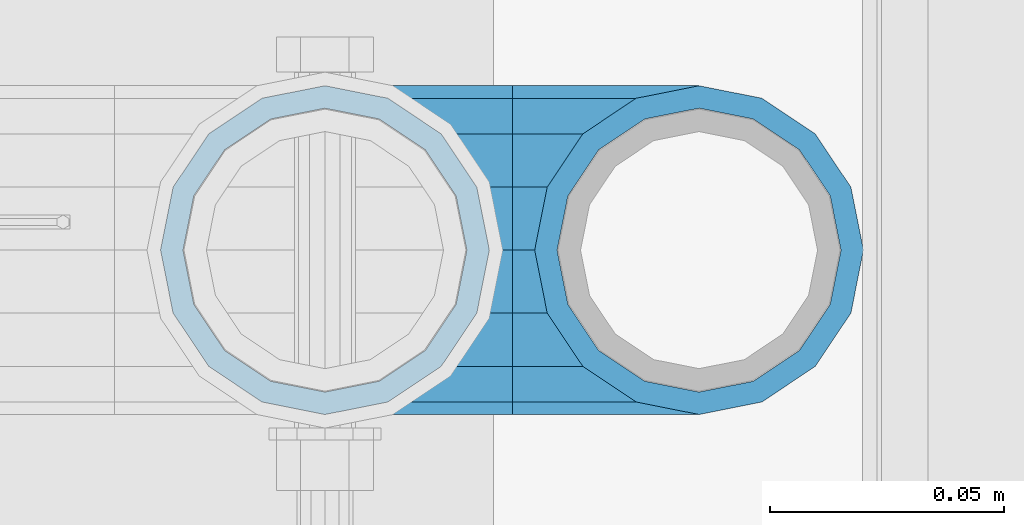
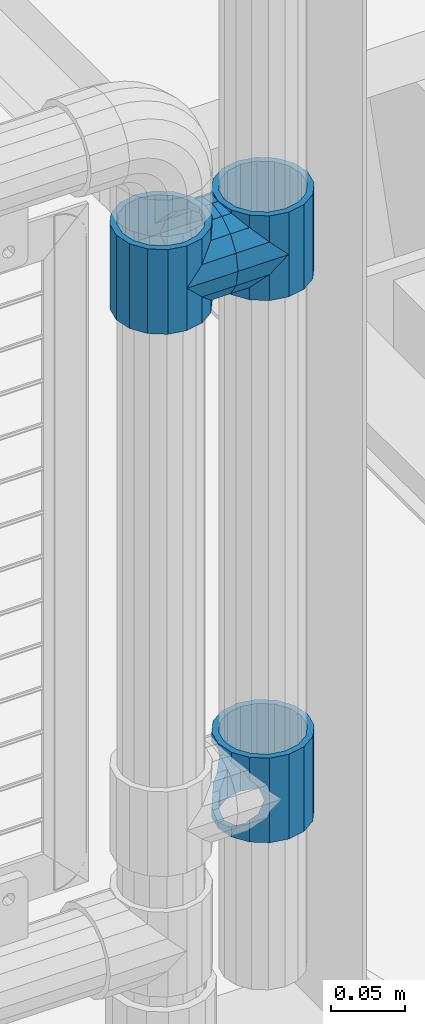
# One storey, part 174 of 257: 5 beams.
"""IFC2X3 building model written with IfcOpenShell, lengths in millimetres."""

import ifcopenshell
import ifcopenshell.guid

model = None  # the IFC model being written
_history = None  # IfcOwnerHistory: only IFC2X3 demands one
_inside = {}  # id of a spatial element -> (the spatial element, [elements in it])
_under = {}  # id of a project, library or spatial element -> (it, [spatial elements below it])
_declared = {}  # id of a project -> (the project, [libraries it declares])
_typed = {}  # id of a type object -> (the type object, [elements of that type])
_made_of = {}  # id of a material, layer set ... -> (it, [elements and type objects made of it])


def new_model(schema):
    """Start an empty IFC model of exactly this schema.

    Asked for "IFC4X3", IfcOpenShell would pick the latest addendum, in which some entities
    have other attributes; the version numbers below select the first issue.
    IFC2X3 requires an IfcOwnerHistory on every rooted entity: one is made here for all.
    """
    global model, _history
    if schema == "IFC4X3":
        model = ifcopenshell.file(schema_version=(4, 3, 0, 0))
    else:
        model = ifcopenshell.file(schema=schema)
    _inside.clear()
    _under.clear()
    _declared.clear()
    _typed.clear()
    _made_of.clear()
    _history = None
    if model.schema == "IFC2X3":
        org = make("IfcOrganization", Name="unknown")
        user = make(
            "IfcPersonAndOrganization",
            ThePerson=make("IfcPerson", FamilyName="unknown"),
            TheOrganization=org,
        )
        app = make(
            "IfcApplication",
            ApplicationDeveloper=org,
            Version="unknown",
            ApplicationFullName="unknown",
            ApplicationIdentifier="unknown",
        )
        _history = make(
            "IfcOwnerHistory",
            OwningUser=user,
            OwningApplication=app,
            ChangeAction="ADDED",
            CreationDate=0,
        )
    return model


def make(cls, **values):
    """One entity of the class cls with the attributes given. An attribute that is None is left unset."""
    return model.create_entity(
        cls, **{name: value for name, value in values.items() if value is not None}
    )


def rooted(cls, **values):
    """An entity with a GlobalId (a new one), such as an element, a storey or a relation."""
    return make(cls, GlobalId=ifcopenshell.guid.new(), OwnerHistory=_history, **values)


def si_unit(unit_type, name, prefix=None):
    """IfcSIUnit, for example si_unit("LENGTHUNIT", "METRE", prefix="MILLI")."""
    return make("IfcSIUnit", UnitType=unit_type, Prefix=prefix, Name=name)


def assignment(units):
    """IfcUnitAssignment: the units of a project."""
    return None if units is None else make("IfcUnitAssignment", Units=units)


def point(xyz):
    """IfcCartesianPoint."""
    return None if xyz is None else make("IfcCartesianPoint", Coordinates=xyz)


def direction(xyz):
    """IfcDirection."""
    return None if xyz is None else make("IfcDirection", DirectionRatios=xyz)


def frame(location, z_axis=None, x_axis=None):
    """IfcAxis2Placement3D, a coordinate frame: its origin and axes. An axis left out is left unset."""
    return make(
        "IfcAxis2Placement3D",
        Location=point(location),
        Axis=direction(z_axis),
        RefDirection=direction(x_axis),
    )


def origin_with_axes():
    """The frame at (0, 0, 0) with the z axis (0, 0, 1) and the x axis (1, 0, 0) written out."""
    return frame((0.0, 0.0, 0.0), z_axis=(0.0, 0.0, 1.0), x_axis=(1.0, 0.0, 0.0))


def place(relative_to, where):
    """IfcLocalPlacement: puts the frame where relative to a parent placement (None: the world)."""
    return make(
        "IfcLocalPlacement", PlacementRelTo=relative_to, RelativePlacement=where
    )


def context(
    kind, dimensions, precision=None, world=None, true_north=None, identifier=None
):
    """IfcGeometricRepresentationContext, for example the 3D "Model" context."""
    return make(
        "IfcGeometricRepresentationContext",
        ContextIdentifier=identifier,
        ContextType=kind,
        CoordinateSpaceDimension=dimensions,
        Precision=precision,
        WorldCoordinateSystem=world,
        TrueNorth=true_north,
    )


def subcontext(parent, identifier, kind, view, scale=None):
    """IfcGeometricRepresentationSubContext, for example "Body" below "Model"."""
    return make(
        "IfcGeometricRepresentationSubContext",
        ContextIdentifier=identifier,
        ContextType=kind,
        ParentContext=parent,
        TargetScale=scale,
        TargetView=view,
    )


def project(units=None, contexts=None):
    """IfcProject with its units and contexts."""
    return rooted(
        "IfcProject",
        Name="project",
        RepresentationContexts=contexts,
        UnitsInContext=assignment(units),
    )


def spatial(cls, under=None, at=None, **own):
    """A site, building, storey or space (cls), placed at a placement, below another one or the project."""
    s = rooted(cls, ObjectPlacement=at, **own)
    if under is not None:
        _under.setdefault(under.id(), (under, []))[1].append(s)
    return s


def faces_of(points, faces, orient=None, outer=None):
    """IfcFace entities. A face is a list of loops; a loop is a list of indices into points, from 0.

    orient and outer hold one flag for each loop. By default every Orientation is true, the
    first loop of a face is its IfcFaceOuterBound and the others are IfcFaceBound.
    """
    made = []
    for i, loops in enumerate(faces):
        bounds = []
        for j, loop in enumerate(loops):
            is_outer = j == 0 if outer is None else outer[i][j]
            bounds.append(
                make(
                    "IfcFaceOuterBound" if is_outer else "IfcFaceBound",
                    Bound=make("IfcPolyLoop", Polygon=[points[k] for k in loop]),
                    Orientation=True if orient is None else orient[i][j],
                )
            )
        made.append(make("IfcFace", Bounds=bounds))
    return made


def faceted_brep(points, faces, orient=None, outer=None, voids=None):
    """IfcFacetedBrep: a solid bounded by flat faces; with voids (closed shells), ...WithVoids."""
    shared = [point(p) for p in points]
    hull = make("IfcClosedShell", CfsFaces=faces_of(shared, faces, orient, outer))
    if voids is None:
        return make("IfcFacetedBrep", Outer=hull)
    return make(
        "IfcFacetedBrepWithVoids",
        Outer=hull,
        Voids=[
            make(cls, CfsFaces=faces_of(shared, fs, o, b)) for cls, fs, o, b in voids
        ],
    )


def shape(context_of_items, identifier, shape_type, items):
    """IfcShapeRepresentation: the items that make up one representation, for example the "Body"."""
    return make(
        "IfcShapeRepresentation",
        ContextOfItems=context_of_items,
        RepresentationIdentifier=identifier,
        RepresentationType=shape_type,
        Items=items,
    )


def material(Name=None, Category=None):
    """IfcMaterial."""
    return make("IfcMaterial", Name=Name, Category=Category)


def made_of(thing, what):
    """Note that an element or type object is made of a material, layer set ...; save() writes the relation."""
    if what is not None:
        _made_of.setdefault(what.id(), (what, []))[1].append(thing)
    return thing


def type_object(cls, material=None, **own):
    """A type object (cls), such as IfcWallType, which elements share."""
    return made_of(rooted(cls, **own), material)


def element(
    cls,
    number,
    at=None,
    inside=None,
    cuts=None,
    type_object=None,
    material=None,
    context=None,
    identifier="Body",
    shape_type=None,
    held_by="IfcProductDefinitionShape",
    body=None,
    shapes=None,
    **own,
):
    """One element of the class cls, such as IfcWall. Its Tag is "e" and its number.

    at: its placement. inside: the storey or other place that contains it. cuts: it is an
    opening in that element (IfcRelVoidsElement). A single representation is given by context,
    identifier, shape_type and body (its items); several are given by shapes. held_by: the class
    of the entity that holds the representations. save() writes the other relations.
    """
    e = rooted(cls, Tag="e%d" % number, ObjectPlacement=at, **own)
    if body is not None:
        shapes = [shape(context, identifier, shape_type, body)]
    if shapes is not None:
        e.Representation = make(held_by, Representations=shapes)
    if inside is not None:
        _inside.setdefault(inside.id(), (inside, []))[1].append(e)
    if cuts is not None:
        rooted(
            "IfcRelVoidsElement", RelatingBuildingElement=cuts, RelatedOpeningElement=e
        )
    if type_object is not None:
        _typed.setdefault(type_object.id(), (type_object, []))[1].append(e)
    return made_of(e, material)


def aggregate(whole, parts):
    """IfcRelAggregates: a whole, such as a stair, and the parts it consists of."""
    return rooted("IfcRelAggregates", RelatingObject=whole, RelatedObjects=parts)


def save(model, path):
    """Write the relations noted so far, then the file.

    IfcRelAggregates (storeys below a building ...), IfcRelContainedInSpatialStructure (elements
    in a storey), IfcRelDefinesByType, IfcRelAssociatesMaterial and IfcRelDeclares: one each for
    every whole, place, type object, material and project.
    """
    for whole, parts in _under.values():
        aggregate(whole, parts)
    for where, things in _inside.values():
        rooted(
            "IfcRelContainedInSpatialStructure",
            RelatedElements=things,
            RelatingStructure=where,
        )
    for kind, things in _typed.values():
        rooted("IfcRelDefinesByType", RelatedObjects=things, RelatingType=kind)
    for what, things in _made_of.values():
        rooted("IfcRelAssociatesMaterial", RelatedObjects=things, RelatingMaterial=what)
    for by, libraries in _declared.values():
        rooted("IfcRelDeclares", RelatingContext=by, RelatedDefinitions=libraries)
    model.write(path)


model = new_model("IFC2X3")

# Units and contexts
model_context = context("Model", 3, precision=1e-05, world=origin_with_axes())
body_context = subcontext(model_context, "Body", "Model", "MODEL_VIEW")
ifc_project = project(units=[si_unit("LENGTHUNIT", "METRE", prefix="MILLI"), si_unit("AREAUNIT", "SQUARE_METRE"), si_unit("VOLUMEUNIT", "CUBIC_METRE"), si_unit("MASSUNIT", "GRAM", prefix="KILO"), si_unit("TIMEUNIT", "SECOND"), si_unit("PLANEANGLEUNIT", "RADIAN"), si_unit("SOLIDANGLEUNIT", "STERADIAN"), si_unit("THERMODYNAMICTEMPERATUREUNIT", "DEGREE_CELSIUS"), si_unit("LUMINOUSINTENSITYUNIT", "LUMEN")], contexts=[model_context])

# Site, building, storey
site_placement = place(None, origin_with_axes())
site = spatial("IfcSite", under=ifc_project, at=site_placement, CompositionType="ELEMENT")
building_placement = place(site_placement, origin_with_axes())
building = spatial("IfcBuilding", under=site, at=building_placement, Name="Standard", CompositionType="ELEMENT")
storey_placement = place(building_placement, origin_with_axes())
storey = spatial("IfcBuildingStorey", under=building, at=storey_placement, Name="Undefined", CompositionType="ELEMENT", Elevation=0.0)

# Beams
ifc_material = material(Name="Misc_Undefined")
beam_type = type_object("IfcBeamType", PredefinedType="NOTDEFINED")
beam_1_placement = place(storey_placement, frame((58751.0, 10664.5, 433.819999999998), z_axis=(1.0, 0.0, 0.0), x_axis=(0.0, 0.0, -1.0)))
element("IfcBeam", 1, at=beam_1_placement, inside=storey, type_object=beam_type, material=ifc_material, context=body_context, shape_type="Brep", body=[
    faceted_brep([(56.6106908090114, 21.4606908090118, -27.1226768591077), (56.6106908090114, 21.4606908090118, -21.4606908090136), (46.7644421722801, 28.0397438117179, -11.6144421722784), (46.7644421722801, 28.0397438117179, -20.0882031229921), (51.5310424080039, 24.8548033587067, -24.8548033587067), (63.1897438117172, 11.6144421722802, -32.8397438117245), (63.1897438117172, 11.6144421722802, -28.0397438117143), (61.9623795176756, 13.4513226476338, -32.4743655677739), (65.4999999999997, 0.0, -35.1500000000015), (65.4999999999997, 0.0, -30.3499999999985), (63.1897438117172, -11.6144421722802, -32.8397438117245), (63.1897438117172, -11.6144421722802, -28.0397438117143), (61.9623795176756, -13.4513226476338, -32.4743655677739), (56.6106908090114, -21.4606908090118, -27.1226768591077), (56.6106908090114, -21.4606908090118, -21.4606908090136), (51.5310424080038, -24.8548033587067, -24.8548033587067), (46.7644421722801, -28.0397438117179, -20.0882031229849), (46.7644421722801, -28.0397438117179, -11.6144421722784), (35.1499999999996, -30.3500000000004, -16.6306603983685), (35.1500000000015, -30.35, 0.0), (23.5355578277191, -28.0397438117179, -20.0882031229849), (23.5355578277191, -28.0397438117179, -11.6144421722784), (13.6893091909879, -21.4606908090118, -27.1226768591077), (13.6893091909879, -21.4606908090118, -21.4606908090136), (18.7689575919987, -24.8548033587067, -24.8548033587067), (7.11025618828205, -11.6144421722802, -32.8397438117245), (7.11025618828205, -11.6144421722802, -28.0397438117143), (8.33762048232484, -13.4513226476338, -32.4743655677739), (4.79999999999961, 0.0, -35.1500000000015), (4.79999999999961, 0.0, -30.3499999999985), (7.11025618828211, 11.6144421722802, -32.8397438117245), (7.11025618828211, 11.6144421722802, -28.0397438117143), (8.3376204823237, 13.4513226476338, -32.4743655677739), (13.6893091909879, 21.4606908090118, -27.1226768591077), (13.6893091909879, 21.4606908090118, -21.4606908090136), (18.7689575919954, 24.8548033587067, -24.8548033587067), (23.5355578277192, 28.0397438117179, -20.0882031229921), (23.5355578277192, 28.0397438117179, -11.6144421722784), (35.1499999999996, 30.3500000000004, -16.6306603983758), (35.1500000000015, 30.35, 0.0), (0.0, 32.4743655677721, -13.4513226476338), (0.0, 35.1499999999996, 0.0), (70.2999999999993, 35.1499999999996, 0.0), (70.2999999999993, 32.4743655677721, -13.4513226476338), (0.0, 32.4743655677721, 13.4513226476338), (70.2999999999993, 32.4743655677721, 13.4513226476338), (0.0, 24.8548033587067, 24.8548033587067), (70.2999999999993, 24.8548033587067, 24.8548033587067), (0.0, 13.4513226476338, 32.4743655677739), (70.2999999999993, 13.4513226476338, 32.4743655677739), (0.0, 0.0, 35.1499999999996), (70.2999999999993, 0.0, 35.1500000000015), (0.0, -13.4513226476338, 32.4743655677739), (70.2999999999993, -13.4513226476338, 32.4743655677739), (0.0, -24.8548033587067, 24.8548033587067), (70.2999999999993, -24.8548033587067, 24.8548033587067), (0.0, -32.4743655677721, 13.4513226476338), (70.2999999999993, -32.4743655677721, 13.4513226476338), (0.0, -35.1499999999996, 0.0), (70.2999999999993, -35.1499999999996, 0.0), (70.2999999999993, -30.3500000000004, 0.0), (70.2999999999993, -28.0397438117179, -11.6144421722784), (70.2999999999993, -21.4606908090118, -21.4606908090136), (70.2999999999993, -11.6144421722802, -28.0397438117143), (70.2999999999993, 0.0, -30.3499999999985), (70.2999999999993, 11.6144421722802, -28.0397438117143), (70.2999999999993, 21.4606908090118, -21.4606908090136), (70.2999999999993, 28.0397438117179, -11.6144421722784), (0.0, -28.0397438117179, -11.6144421722784), (0.0, -30.3500000000004, 0.0), (0.0, -21.4606908090118, -21.4606908090136), (0.0, -11.6144421722802, -28.0397438117143), (0.0, 0.0, -30.3499999999985), (0.0, 11.6144421722802, -28.0397438117143), (0.0, 21.4606908090118, -21.4606908090136), (0.0, 28.0397438117179, -11.6144421722784), (0.0, 30.3500000000004, 0.0), (70.2999999999993, 30.3500000000004, 0.0), (0.0, 28.0397438117179, 11.6144421722784), (70.2999999999993, 28.0397438117179, 11.6144421722784), (0.0, 21.4606908090118, 21.4606908090136), (70.2999999999993, 21.4606908090118, 21.4606908090136), (0.0, 11.6144421722802, 28.0397438117143), (70.2999999999993, 11.6144421722802, 28.0397438117143), (0.0, 0.0, 30.3499999999985), (70.2999999999993, 0.0, 30.3499999999985), (0.0, -11.6144421722802, 28.0397438117143), (70.2999999999993, -11.6144421722802, 28.0397438117143), (0.0, -21.4606908090118, 21.4606908090136), (70.2999999999993, -21.4606908090118, 21.4606908090136), (0.0, -28.0397438117179, 11.6144421722784), (70.2999999999993, -28.0397438117179, 11.6144421722784), (70.2999999999993, -24.8548033587067, -24.8548033587067), (70.2999999999993, -13.4513226476338, -32.4743655677739), (70.2999999999993, 0.0, -35.1500000000015), (70.2999999999993, 13.4513226476338, -32.4743655677739), (70.2999999999993, 24.8548033587067, -24.8548033587067), (70.2999999999993, -32.4743655677721, -13.4513226476338), (0.0, -32.4743655677721, -13.4513226476338), (0.0, 24.8548033587067, -24.8548033587067), (0.0, 13.4513226476338, -32.4743655677739), (0.0, 0.0, -35.1499999999996), (0.0, -13.4513226476338, -32.4743655677739), (0.0, -24.8548033587067, -24.8548033587067)], [[[0, 1, 2, 3, 4]], [[5, 6, 1, 0, 7]], [[8, 9, 6, 5]], [[10, 11, 9, 8]], [[12, 13, 14, 11, 10]], [[15, 16, 17, 14, 13]], [[18, 19, 17, 16]], [[20, 21, 19, 18]], [[22, 23, 21, 20, 24]], [[25, 26, 23, 22, 27]], [[28, 29, 26, 25]], [[30, 31, 29, 28]], [[32, 33, 34, 31, 30]], [[35, 36, 37, 34, 33]], [[38, 39, 37, 36]], [[3, 2, 39, 38]], [[40, 41, 42, 43]], [[41, 44, 45, 42]], [[44, 46, 47, 45]], [[46, 48, 49, 47]], [[48, 50, 51, 49]], [[50, 52, 53, 51]], [[52, 54, 55, 53]], [[54, 56, 57, 55]], [[56, 58, 59, 57]], [[60, 61, 17, 19]], [[61, 62, 14, 17]], [[62, 63, 11, 14]], [[63, 64, 9, 11]], [[64, 65, 6, 9]], [[65, 66, 1, 6]], [[66, 67, 2, 1]], [[68, 69, 19, 21]], [[70, 68, 21, 23]], [[71, 70, 23, 26]], [[72, 71, 26, 29]], [[73, 72, 29, 31]], [[74, 73, 31, 34]], [[75, 74, 34, 37]], [[76, 75, 37, 39]], [[67, 77, 39, 2]], [[78, 76, 39, 77, 79]], [[80, 78, 79, 81]], [[82, 80, 81, 83]], [[84, 82, 83, 85]], [[86, 84, 85, 87]], [[88, 86, 87, 89]], [[90, 88, 89, 91]], [[19, 69, 90, 91, 60]], [[92, 93, 94, 95, 96, 43, 42, 45, 47, 49, 51, 53, 55, 57, 59, 97], [89, 87, 85, 83, 81, 79, 77, 67, 66, 65, 64, 63, 62, 61, 60, 91]], [[58, 98, 97, 59]], [[56, 54, 52, 50, 48, 46, 44, 41, 40, 99, 100, 101, 102, 103, 98, 58], [68, 70, 71, 72, 73, 74, 75, 76, 78, 80, 82, 84, 86, 88, 90, 69]], [[100, 99, 35, 33, 32]], [[101, 100, 32, 30, 28]], [[27, 102, 101, 28, 25]], [[24, 103, 102, 27, 22]], [[92, 97, 98, 103, 24, 20, 18, 16, 15]], [[93, 92, 15, 13, 12]], [[94, 93, 12, 10, 8]], [[7, 95, 94, 8, 5]], [[4, 96, 95, 7, 0]], [[38, 36, 35, 99, 40, 43, 96, 4, 3]]]),
])
beam_2_placement = place(storey_placement, frame((58671.0, 10664.5, 848.669999999998), z_axis=(0.0, -1.0, 0.0), x_axis=(1.0, 0.0, 0.0)))
element("IfcBeam", 2, at=beam_2_placement, inside=storey, type_object=beam_type, material=ifc_material, context=body_context, shape_type="Brep", body=[
    faceted_brep([(13.4513226476338, -13.4513226476329, -32.4743655677721), (13.4513226476338, 13.4513226476329, -32.4743655677721), (0.0, 0.0, -35.1499999999996), (27.122676859115, 21.4606908090117, 21.4606908090118), (24.8548033587067, 16.3810424080013, 24.8548033587067), (24.8548033587067, 24.8548033587072, 24.8548033587067), (32.4743655677739, 32.4743655677717, 13.4513226476338), (32.4743655677739, 26.8123795176755, 13.4513226476338), (0.0, 0.0, 35.1499999999996), (13.4513226476338, 13.4513226476329, 32.4743655677721), (13.4513226476338, -13.4513226476329, 32.4743655677721), (20.0882031229849, 11.6144421722805, 28.0397438117179), (16.6306603983758, 0.0, 30.3500000000004), (20.0882031229849, -11.6144421722805, 28.0397438117179), (24.8548033587067, -16.3810424080013, 24.8548033587067), (24.8548033587067, -24.8548033587072, 24.8548033587067), (27.122676859115, -21.4606908090117, 21.4606908090118), (32.4743655677739, -26.8123795176754, 13.4513226476338), (32.4743655677739, -32.4743655677717, 13.4513226476338), (32.8397438117172, -28.0397438117175, 11.6144421722802), (35.1500000000015, -30.35, 0.0), (35.1500000000015, -35.1499999999996, 0.0), (32.8397438117172, -28.0397438117175, -11.6144421722802), (32.4743655677739, -26.8123795176755, -13.4513226476338), (32.4743655677739, -32.4743655677717, -13.4513226476338), (27.1226768591005, -21.4606908090117, -21.4606908090118), (24.8548033587067, -16.3810424080045, -24.8548033587067), (24.8548033587067, -24.8548033587072, -24.8548033587067), (20.0882031229849, -11.6144421722805, -28.0397438117179), (16.6306603983685, 0.0, -30.3500000000004), (20.0882031229849, 11.6144421722805, -28.0397438117179), (24.8548033587067, 16.3810424080013, -24.8548033587067), (24.8548033587067, 24.8548033587072, -24.8548033587067), (32.4743655677739, 26.8123795176754, -13.4513226476338), (32.4743655677739, 32.4743655677717, -13.4513226476338), (27.1226768591005, 21.4606908090117, -21.4606908090118), (35.1500000000015, 30.35, 0.0), (35.1500000000015, 35.15, 0.0), (32.8397438117172, 28.0397438117175, -11.6144421722802), (32.8397438117172, 28.0397438117175, 11.6144421722802), (40.1500000000015, -35.15, 0.0), (40.1500000000015, -32.4743655677717, 13.4513226476338), (40.1500000000015, -24.8548033587072, 24.8548033587067), (40.1500000000015, -13.4513226476329, 32.4743655677721), (40.1500000000015, 0.0, 35.1499999999996), (40.1500000000015, 13.4513226476329, 32.4743655677721), (40.1500000000015, 24.8548033587072, 24.8548033587067), (40.1500000000015, 32.4743655677717, 13.4513226476338), (40.1500000000015, 35.15, 0.0), (40.1500000000015, -24.8548033587072, -24.8548033587067), (40.1500000000015, -32.4743655677717, -13.4513226476338), (40.1500000000015, -13.4513226476329, -32.4743655677721), (40.1500000000015, 0.0, -35.1499999999996), (40.1500000000015, 13.4513226476329, -32.4743655677721), (40.1500000000015, 24.8548033587072, -24.8548033587067), (40.1500000000015, 32.4743655677717, -13.4513226476338), (40.1500000000015, -21.4606908090117, 21.4606908090118), (40.1500000000015, -11.6144421722805, 28.0397438117179), (40.1500000000015, 0.0, 30.3500000000004), (40.1500000000015, 11.6144421722805, 28.0397438117179), (40.1500000000015, 21.4606908090117, 21.4606908090118), (40.1500000000015, 28.0397438117175, 11.6144421722802), (40.1500000000015, 30.35, 0.0), (40.1500000000015, 28.0397438117175, -11.6144421722802), (40.1500000000015, 21.4606908090117, -21.4606908090118), (40.1500000000015, 11.6144421722805, -28.0397438117179), (40.1500000000015, 0.0, -30.3500000000004), (40.1500000000015, -11.6144421722805, -28.0397438117179), (40.1500000000015, -21.4606908090117, -21.4606908090118), (40.1500000000015, -28.0397438117175, -11.6144421722802), (40.1500000000015, -30.35, 0.0), (40.1500000000015, -28.0397438117175, 11.6144421722802)], [[[0, 1, 2]], [[3, 4, 5, 6, 7]], [[8, 9, 10]], [[10, 9, 5, 4, 11, 12, 13, 14, 15]], [[15, 14, 16, 17, 18]], [[18, 17, 19, 20, 21]], [[21, 20, 22, 23, 24]], [[24, 23, 25, 26, 27]], [[27, 26, 28, 29, 30, 31, 32, 1, 0]], [[33, 34, 32, 31, 35]], [[36, 37, 34, 33, 38]], [[39, 7, 6, 37, 36]], [[40, 41, 18, 21]], [[41, 42, 15, 18]], [[42, 43, 10, 15]], [[43, 44, 8, 10]], [[44, 45, 9, 8]], [[45, 46, 5, 9]], [[46, 47, 6, 5]], [[47, 48, 37, 6]], [[49, 50, 24, 27]], [[51, 49, 27, 0]], [[52, 51, 0, 2]], [[53, 52, 2, 1]], [[54, 53, 1, 32]], [[55, 54, 32, 34]], [[48, 55, 34, 37]], [[50, 40, 21, 24]], [[49, 51, 52, 53, 54, 55, 48, 47, 46, 45, 44, 43, 42, 41, 40, 50], [56, 57, 58, 59, 60, 61, 62, 63, 64, 65, 66, 67, 68, 69, 70, 71]], [[63, 62, 36, 38]], [[35, 64, 63, 38, 33]], [[30, 65, 64, 35, 31]], [[66, 65, 30, 29]], [[67, 66, 29, 28]], [[68, 67, 28, 26, 25]], [[69, 68, 25, 23, 22]], [[70, 69, 22, 20]], [[71, 70, 20, 19]], [[16, 56, 71, 19, 17]], [[13, 57, 56, 16, 14]], [[58, 57, 13, 12]], [[59, 58, 12, 11]], [[60, 59, 11, 4, 3]], [[61, 60, 3, 7, 39]], [[62, 61, 39, 36]]]),
])
beam_3_placement = place(storey_placement, frame((58751.0, 10664.5, 848.669999999998), z_axis=(0.0, 1.0, 0.0), x_axis=(-1.0, 0.0, 0.0)))
element("IfcBeam", 3, at=beam_3_placement, inside=storey, type_object=beam_type, material=ifc_material, context=body_context, shape_type="Brep", body=[
    faceted_brep([(13.4513226476338, -13.4513226476329, -32.4743655677721), (13.4513226476338, 13.4513226476329, -32.4743655677721), (0.0, 0.0, -35.1499999999996), (24.8548033587067, -24.8548033587072, 24.8548033587067), (24.8548033587067, -16.3810424080013, 24.8548033587067), (27.122676859115, -21.4606908090117, 21.4606908090118), (32.4743655677739, -26.8123795176754, 13.4513226476338), (32.4743655677739, -32.4743655677717, 13.4513226476338), (32.8397438117172, -28.0397438117175, 11.6144421722802), (35.1500000000015, -30.35, 0.0), (35.1500000000015, -35.1499999999996, 0.0), (32.8397438117172, -28.0397438117175, -11.6144421722802), (32.4743655677739, -26.8123795176755, -13.4513226476338), (32.4743655677739, -32.4743655677717, -13.4513226476338), (27.1226768591005, -21.4606908090117, -21.4606908090118), (24.8548033587067, -16.3810424080045, -24.8548033587067), (24.8548033587067, -24.8548033587072, -24.8548033587067), (20.0882031229849, -11.6144421722805, -28.0397438117179), (16.6306603983685, 0.0, -30.3500000000004), (20.0882031229849, 11.6144421722805, -28.0397438117179), (24.8548033587067, 16.3810424080013, -24.8548033587067), (24.8548033587067, 24.8548033587072, -24.8548033587067), (32.4743655677739, 26.8123795176754, -13.4513226476338), (32.4743655677739, 32.4743655677717, -13.4513226476338), (27.1226768591005, 21.4606908090117, -21.4606908090118), (35.1500000000015, 30.35, 0.0), (35.1500000000015, 35.15, 0.0), (32.8397438117172, 28.0397438117175, -11.6144421722802), (32.8397438117172, 28.0397438117175, 11.6144421722802), (32.4743655677739, 26.8123795176755, 13.4513226476338), (32.4743655677739, 32.4743655677717, 13.4513226476338), (27.122676859115, 21.4606908090117, 21.4606908090118), (24.8548033587067, 16.3810424080013, 24.8548033587067), (24.8548033587067, 24.8548033587072, 24.8548033587067), (0.0, 0.0, 35.1499999999996), (13.4513226476338, 13.4513226476329, 32.4743655677721), (13.4513226476338, -13.4513226476329, 32.4743655677721), (20.0882031229849, 11.6144421722805, 28.0397438117179), (16.6306603983758, 0.0, 30.3500000000004), (20.0882031229849, -11.6144421722805, 28.0397438117179), (40.1500000000015, -35.15, 0.0), (40.1500000000015, -32.4743655677717, 13.4513226476338), (40.1500000000015, -24.8548033587072, 24.8548033587067), (40.1500000000015, -13.4513226476329, 32.4743655677721), (40.1500000000015, 0.0, 35.1499999999996), (40.1500000000015, -24.8548033587072, -24.8548033587067), (40.1500000000015, -32.4743655677717, -13.4513226476338), (40.1500000000015, -13.4513226476329, -32.4743655677721), (40.1500000000015, 0.0, -35.1499999999996), (40.1500000000015, 13.4513226476329, -32.4743655677721), (40.1500000000015, 24.8548033587072, -24.8548033587067), (40.1500000000015, 32.4743655677717, -13.4513226476338), (40.1500000000015, 35.15, 0.0), (40.1500000000015, 32.4743655677717, 13.4513226476338), (40.1500000000015, 24.8548033587072, 24.8548033587067), (40.1500000000015, 13.4513226476329, 32.4743655677721), (40.1500000000015, -21.4606908090117, 21.4606908090118), (40.1500000000015, -11.6144421722805, 28.0397438117179), (40.1500000000015, 0.0, 30.3500000000004), (40.1500000000015, 11.6144421722805, 28.0397438117179), (40.1500000000015, 21.4606908090117, 21.4606908090118), (40.1500000000015, 28.0397438117175, 11.6144421722802), (40.1500000000015, 30.35, 0.0), (40.1500000000015, 28.0397438117175, -11.6144421722802), (40.1500000000015, 21.4606908090117, -21.4606908090118), (40.1500000000015, 11.6144421722805, -28.0397438117179), (40.1500000000015, 0.0, -30.3500000000004), (40.1500000000015, -11.6144421722805, -28.0397438117179), (40.1500000000015, -21.4606908090117, -21.4606908090118), (40.1500000000015, -28.0397438117175, -11.6144421722802), (40.1500000000015, -30.35, 0.0), (40.1500000000015, -28.0397438117175, 11.6144421722802)], [[[0, 1, 2]], [[3, 4, 5, 6, 7]], [[7, 6, 8, 9, 10]], [[10, 9, 11, 12, 13]], [[13, 12, 14, 15, 16]], [[16, 15, 17, 18, 19, 20, 21, 1, 0]], [[22, 23, 21, 20, 24]], [[25, 26, 23, 22, 27]], [[28, 29, 30, 26, 25]], [[31, 32, 33, 30, 29]], [[34, 35, 36]], [[36, 35, 33, 32, 37, 38, 39, 4, 3]], [[40, 41, 7, 10]], [[41, 42, 3, 7]], [[42, 43, 36, 3]], [[43, 44, 34, 36]], [[45, 46, 13, 16]], [[47, 45, 16, 0]], [[48, 47, 0, 2]], [[49, 48, 2, 1]], [[50, 49, 1, 21]], [[51, 50, 21, 23]], [[52, 51, 23, 26]], [[53, 52, 26, 30]], [[54, 53, 30, 33]], [[55, 54, 33, 35]], [[44, 55, 35, 34]], [[46, 40, 10, 13]], [[45, 47, 48, 49, 50, 51, 52, 53, 54, 55, 44, 43, 42, 41, 40, 46], [56, 57, 58, 59, 60, 61, 62, 63, 64, 65, 66, 67, 68, 69, 70, 71]], [[59, 58, 38, 37]], [[60, 59, 37, 32, 31]], [[61, 60, 31, 29, 28]], [[62, 61, 28, 25]], [[63, 62, 25, 27]], [[24, 64, 63, 27, 22]], [[19, 65, 64, 24, 20]], [[66, 65, 19, 18]], [[67, 66, 18, 17]], [[68, 67, 17, 15, 14]], [[69, 68, 14, 12, 11]], [[70, 69, 11, 9]], [[71, 70, 9, 8]], [[5, 56, 71, 8, 6]], [[39, 57, 56, 5, 4]], [[58, 57, 39, 38]]]),
])
beam_4_placement = place(storey_placement, frame((58671.0, 10664.5, 883.819999999998), z_axis=(-1.0, 0.0, 0.0), x_axis=(0.0, 0.0, -1.0)))
element("IfcBeam", 4, at=beam_4_placement, inside=storey, type_object=beam_type, material=ifc_material, context=body_context, shape_type="Brep", body=[
    faceted_brep([(7.11025618828205, -11.6144421722802, -32.8397438117245), (7.11025618828205, -11.6144421722802, -28.0397438117143), (13.6893091909879, -21.4606908090118, -21.4606908090136), (13.6893091909879, -21.4606908090118, -27.1226768591077), (8.33762048232484, -13.4513226476338, -32.4743655677739), (23.5355578277191, -28.0397438117179, -11.6144421722784), (23.5355578277191, -28.0397438117179, -20.0882031229849), (18.7689575919987, -24.8548033587067, -24.8548033587067), (35.1500000000015, -30.35, 0.0), (35.1499999999996, -30.3500000000004, -16.6306603983685), (46.7644421722801, -28.0397438117179, -11.6144421722784), (46.7644421722801, -28.0397438117179, -20.0882031229849), (51.5310424080038, -24.8548033587067, -24.8548033587067), (56.6106908090114, -21.4606908090118, -21.4606908090136), (56.6106908090114, -21.4606908090118, -27.1226768591077), (61.9623795176756, -13.4513226476338, -32.4743655677739), (63.1897438117172, -11.6144421722802, -28.0397438117143), (63.1897438117172, -11.6144421722802, -32.8397438117245), (65.4999999999997, 0.0, -30.3499999999985), (65.4999999999997, 0.0, -35.1500000000015), (63.1897438117172, 11.6144421722802, -28.0397438117143), (63.1897438117172, 11.6144421722802, -32.8397438117245), (56.6106908090114, 21.4606908090118, -21.4606908090136), (56.6106908090114, 21.4606908090118, -27.1226768591077), (61.9623795176756, 13.4513226476338, -32.4743655677739), (46.7644421722801, 28.0397438117179, -11.6144421722784), (46.7644421722801, 28.0397438117179, -20.0882031229921), (51.5310424080039, 24.8548033587067, -24.8548033587067), (35.1500000000015, 30.35, 0.0), (35.1499999999996, 30.3500000000004, -16.6306603983758), (23.5355578277192, 28.0397438117179, -11.6144421722784), (23.5355578277192, 28.0397438117179, -20.0882031229921), (18.7689575919954, 24.8548033587067, -24.8548033587067), (13.6893091909879, 21.4606908090118, -21.4606908090136), (13.6893091909879, 21.4606908090118, -27.1226768591077), (8.3376204823237, 13.4513226476338, -32.4743655677739), (7.11025618828211, 11.6144421722802, -28.0397438117143), (7.11025618828211, 11.6144421722802, -32.8397438117245), (4.79999999999961, 0.0, -30.3499999999985), (4.79999999999961, 0.0, -35.1500000000015), (0.0, 21.4606908090118, 21.4606908090136), (0.0, 28.0397438117179, 11.6144421722784), (70.2999999999993, 28.0397438117179, 11.6144421722784), (70.2999999999993, 21.4606908090118, 21.4606908090136), (0.0, 11.6144421722802, 28.0397438117143), (70.2999999999993, 11.6144421722802, 28.0397438117143), (0.0, 0.0, 30.3499999999985), (70.2999999999993, 0.0, 30.3499999999985), (0.0, -11.6144421722802, 28.0397438117143), (70.2999999999993, -11.6144421722802, 28.0397438117143), (0.0, -21.4606908090118, 21.4606908090136), (70.2999999999993, -21.4606908090118, 21.4606908090136), (0.0, -28.0397438117179, 11.6144421722784), (70.2999999999993, -28.0397438117179, 11.6144421722784), (0.0, -24.8548033587067, -24.8548033587067), (0.0, -13.4513226476338, -32.4743655677739), (0.0, 0.0, -35.1499999999996), (0.0, -32.4743655677721, 13.4513226476338), (0.0, -35.1499999999996, 0.0), (70.2999999999993, -35.1499999999996, 0.0), (70.2999999999993, -32.4743655677721, 13.4513226476338), (0.0, -24.8548033587067, 24.8548033587067), (70.2999999999993, -24.8548033587067, 24.8548033587067), (0.0, -13.4513226476338, 32.4743655677739), (70.2999999999993, -13.4513226476338, 32.4743655677739), (0.0, 0.0, 35.1499999999996), (70.2999999999993, 0.0, 35.1500000000015), (0.0, 13.4513226476338, 32.4743655677739), (70.2999999999993, 13.4513226476338, 32.4743655677739), (0.0, 24.8548033587067, 24.8548033587067), (70.2999999999993, 24.8548033587067, 24.8548033587067), (0.0, 32.4743655677721, 13.4513226476338), (70.2999999999993, 32.4743655677721, 13.4513226476338), (0.0, 35.1499999999996, 0.0), (70.2999999999993, 35.1499999999996, 0.0), (0.0, 32.4743655677721, -13.4513226476338), (70.2999999999993, 32.4743655677721, -13.4513226476338), (70.2999999999993, -13.4513226476338, -32.4743655677739), (70.2999999999993, -24.8548033587067, -24.8548033587067), (70.2999999999993, 0.0, -35.1500000000015), (70.2999999999993, 13.4513226476338, -32.4743655677739), (70.2999999999993, 24.8548033587067, -24.8548033587067), (0.0, 24.8548033587067, -24.8548033587067), (0.0, 13.4513226476338, -32.4743655677739), (70.2999999999993, -32.4743655677721, -13.4513226476338), (0.0, -32.4743655677721, -13.4513226476338), (0.0, -28.0397438117179, -11.6144421722784), (0.0, -21.4606908090118, -21.4606908090136), (0.0, -11.6144421722802, -28.0397438117143), (0.0, 0.0, -30.3499999999985), (0.0, 11.6144421722802, -28.0397438117143), (0.0, 21.4606908090118, -21.4606908090136), (0.0, 28.0397438117179, -11.6144421722784), (0.0, 30.3500000000004, 0.0), (0.0, -30.3500000000004, 0.0), (70.2999999999993, 30.3500000000004, 0.0), (70.2999999999993, 28.0397438117179, -11.6144421722784), (70.2999999999993, 21.4606908090118, -21.4606908090136), (70.2999999999993, 11.6144421722802, -28.0397438117143), (70.2999999999993, 0.0, -30.3499999999985), (70.2999999999993, -11.6144421722802, -28.0397438117143), (70.2999999999993, -21.4606908090118, -21.4606908090136), (70.2999999999993, -28.0397438117179, -11.6144421722784), (70.2999999999993, -30.3500000000004, 0.0)], [[[0, 1, 2, 3, 4]], [[3, 2, 5, 6, 7]], [[6, 5, 8, 9]], [[9, 8, 10, 11]], [[12, 11, 10, 13, 14]], [[15, 14, 13, 16, 17]], [[17, 16, 18, 19]], [[19, 18, 20, 21]], [[21, 20, 22, 23, 24]], [[23, 22, 25, 26, 27]], [[26, 25, 28, 29]], [[29, 28, 30, 31]], [[32, 31, 30, 33, 34]], [[35, 34, 33, 36, 37]], [[37, 36, 38, 39]], [[39, 38, 1, 0]], [[40, 41, 42, 43]], [[44, 40, 43, 45]], [[46, 44, 45, 47]], [[48, 46, 47, 49]], [[50, 48, 49, 51]], [[52, 50, 51, 53]], [[7, 54, 55, 4, 3]], [[4, 55, 56, 39, 0]], [[57, 58, 59, 60]], [[61, 57, 60, 62]], [[63, 61, 62, 64]], [[65, 63, 64, 66]], [[67, 65, 66, 68]], [[69, 67, 68, 70]], [[71, 69, 70, 72]], [[73, 71, 72, 74]], [[75, 73, 74, 76]], [[77, 78, 12, 14, 15]], [[79, 77, 15, 17, 19]], [[24, 80, 79, 19, 21]], [[27, 81, 80, 24, 23]], [[29, 31, 32, 82, 75, 76, 81, 27, 26]], [[83, 82, 32, 34, 35]], [[56, 83, 35, 37, 39]], [[78, 84, 85, 54, 7, 6, 9, 11, 12]], [[58, 85, 84, 59]], [[57, 61, 63, 65, 67, 69, 71, 73, 75, 82, 83, 56, 55, 54, 85, 58], [86, 87, 88, 89, 90, 91, 92, 93, 41, 40, 44, 46, 48, 50, 52, 94]], [[90, 89, 38, 36]], [[91, 90, 36, 33]], [[92, 91, 33, 30]], [[93, 92, 30, 28]], [[41, 93, 28, 95, 42]], [[96, 95, 28, 25]], [[97, 96, 25, 22]], [[98, 97, 22, 20]], [[99, 98, 20, 18]], [[100, 99, 18, 16]], [[101, 100, 16, 13]], [[102, 101, 13, 10]], [[103, 102, 10, 8]], [[78, 77, 79, 80, 81, 76, 74, 72, 70, 68, 66, 64, 62, 60, 59, 84], [51, 49, 47, 45, 43, 42, 95, 96, 97, 98, 99, 100, 101, 102, 103, 53]], [[8, 94, 52, 53, 103]], [[86, 94, 8, 5]], [[87, 86, 5, 2]], [[88, 87, 2, 1]], [[89, 88, 1, 38]]]),
])
beam_5_placement = place(storey_placement, frame((58751.0, 10664.5, 883.819999999998), z_axis=(1.0, 0.0, 0.0), x_axis=(0.0, 0.0, -1.0)))
element("IfcBeam", 5, at=beam_5_placement, inside=storey, type_object=beam_type, material=ifc_material, context=body_context, shape_type="Brep", body=[
    faceted_brep([(56.6106908090114, 21.4606908090118, -27.1226768591077), (56.6106908090114, 21.4606908090118, -21.4606908090136), (46.7644421722801, 28.0397438117179, -11.6144421722784), (46.7644421722801, 28.0397438117179, -20.0882031229921), (51.5310424080039, 24.8548033587067, -24.8548033587067), (63.1897438117172, 11.6144421722802, -32.8397438117245), (63.1897438117172, 11.6144421722802, -28.0397438117143), (61.9623795176756, 13.4513226476338, -32.4743655677739), (65.4999999999997, 0.0, -35.1500000000015), (65.4999999999997, 0.0, -30.3499999999985), (63.1897438117172, -11.6144421722802, -32.8397438117245), (63.1897438117172, -11.6144421722802, -28.0397438117143), (61.9623795176756, -13.4513226476338, -32.4743655677739), (56.6106908090114, -21.4606908090118, -27.1226768591077), (56.6106908090114, -21.4606908090118, -21.4606908090136), (51.5310424080038, -24.8548033587067, -24.8548033587067), (46.7644421722801, -28.0397438117179, -20.0882031229849), (46.7644421722801, -28.0397438117179, -11.6144421722784), (35.1499999999996, -30.3500000000004, -16.6306603983685), (35.1500000000015, -30.35, 0.0), (23.5355578277191, -28.0397438117179, -20.0882031229849), (23.5355578277191, -28.0397438117179, -11.6144421722784), (13.6893091909879, -21.4606908090118, -27.1226768591077), (13.6893091909879, -21.4606908090118, -21.4606908090136), (18.7689575919987, -24.8548033587067, -24.8548033587067), (7.11025618828205, -11.6144421722802, -32.8397438117245), (7.11025618828205, -11.6144421722802, -28.0397438117143), (8.33762048232484, -13.4513226476338, -32.4743655677739), (4.79999999999961, 0.0, -35.1500000000015), (4.79999999999961, 0.0, -30.3499999999985), (7.11025618828211, 11.6144421722802, -32.8397438117245), (7.11025618828211, 11.6144421722802, -28.0397438117143), (8.3376204823237, 13.4513226476338, -32.4743655677739), (13.6893091909879, 21.4606908090118, -27.1226768591077), (13.6893091909879, 21.4606908090118, -21.4606908090136), (18.7689575919954, 24.8548033587067, -24.8548033587067), (23.5355578277192, 28.0397438117179, -20.0882031229921), (23.5355578277192, 28.0397438117179, -11.6144421722784), (35.1499999999996, 30.3500000000004, -16.6306603983758), (35.1500000000015, 30.35, 0.0), (0.0, 32.4743655677721, -13.4513226476338), (0.0, 35.1499999999996, 0.0), (70.2999999999993, 35.1499999999996, 0.0), (70.2999999999993, 32.4743655677721, -13.4513226476338), (0.0, 32.4743655677721, 13.4513226476338), (70.2999999999993, 32.4743655677721, 13.4513226476338), (0.0, 24.8548033587067, 24.8548033587067), (70.2999999999993, 24.8548033587067, 24.8548033587067), (0.0, 13.4513226476338, 32.4743655677739), (70.2999999999993, 13.4513226476338, 32.4743655677739), (0.0, 0.0, 35.1499999999996), (70.2999999999993, 0.0, 35.1500000000015), (0.0, -13.4513226476338, 32.4743655677739), (70.2999999999993, -13.4513226476338, 32.4743655677739), (0.0, -24.8548033587067, 24.8548033587067), (70.2999999999993, -24.8548033587067, 24.8548033587067), (0.0, -32.4743655677721, 13.4513226476338), (70.2999999999993, -32.4743655677721, 13.4513226476338), (0.0, -35.1499999999996, 0.0), (70.2999999999993, -35.1499999999996, 0.0), (70.2999999999993, -30.3500000000004, 0.0), (70.2999999999993, -28.0397438117179, -11.6144421722784), (70.2999999999993, -21.4606908090118, -21.4606908090136), (70.2999999999993, -11.6144421722802, -28.0397438117143), (70.2999999999993, 0.0, -30.3499999999985), (70.2999999999993, 11.6144421722802, -28.0397438117143), (70.2999999999993, 21.4606908090118, -21.4606908090136), (70.2999999999993, 28.0397438117179, -11.6144421722784), (0.0, -28.0397438117179, -11.6144421722784), (0.0, -30.3500000000004, 0.0), (0.0, -21.4606908090118, -21.4606908090136), (0.0, -11.6144421722802, -28.0397438117143), (0.0, 0.0, -30.3499999999985), (0.0, 11.6144421722802, -28.0397438117143), (0.0, 21.4606908090118, -21.4606908090136), (0.0, 28.0397438117179, -11.6144421722784), (0.0, 30.3500000000004, 0.0), (70.2999999999993, 30.3500000000004, 0.0), (0.0, 28.0397438117179, 11.6144421722784), (70.2999999999993, 28.0397438117179, 11.6144421722784), (0.0, 21.4606908090118, 21.4606908090136), (70.2999999999993, 21.4606908090118, 21.4606908090136), (0.0, 11.6144421722802, 28.0397438117143), (70.2999999999993, 11.6144421722802, 28.0397438117143), (0.0, 0.0, 30.3499999999985), (70.2999999999993, 0.0, 30.3499999999985), (0.0, -11.6144421722802, 28.0397438117143), (70.2999999999993, -11.6144421722802, 28.0397438117143), (0.0, -21.4606908090118, 21.4606908090136), (70.2999999999993, -21.4606908090118, 21.4606908090136), (0.0, -28.0397438117179, 11.6144421722784), (70.2999999999993, -28.0397438117179, 11.6144421722784), (70.2999999999993, -24.8548033587067, -24.8548033587067), (70.2999999999993, -13.4513226476338, -32.4743655677739), (70.2999999999993, 0.0, -35.1500000000015), (70.2999999999993, 13.4513226476338, -32.4743655677739), (70.2999999999993, 24.8548033587067, -24.8548033587067), (70.2999999999993, -32.4743655677721, -13.4513226476338), (0.0, -32.4743655677721, -13.4513226476338), (0.0, 24.8548033587067, -24.8548033587067), (0.0, 13.4513226476338, -32.4743655677739), (0.0, 0.0, -35.1499999999996), (0.0, -13.4513226476338, -32.4743655677739), (0.0, -24.8548033587067, -24.8548033587067)], [[[0, 1, 2, 3, 4]], [[5, 6, 1, 0, 7]], [[8, 9, 6, 5]], [[10, 11, 9, 8]], [[12, 13, 14, 11, 10]], [[15, 16, 17, 14, 13]], [[18, 19, 17, 16]], [[20, 21, 19, 18]], [[22, 23, 21, 20, 24]], [[25, 26, 23, 22, 27]], [[28, 29, 26, 25]], [[30, 31, 29, 28]], [[32, 33, 34, 31, 30]], [[35, 36, 37, 34, 33]], [[38, 39, 37, 36]], [[3, 2, 39, 38]], [[40, 41, 42, 43]], [[41, 44, 45, 42]], [[44, 46, 47, 45]], [[46, 48, 49, 47]], [[48, 50, 51, 49]], [[50, 52, 53, 51]], [[52, 54, 55, 53]], [[54, 56, 57, 55]], [[56, 58, 59, 57]], [[60, 61, 17, 19]], [[61, 62, 14, 17]], [[62, 63, 11, 14]], [[63, 64, 9, 11]], [[64, 65, 6, 9]], [[65, 66, 1, 6]], [[66, 67, 2, 1]], [[68, 69, 19, 21]], [[70, 68, 21, 23]], [[71, 70, 23, 26]], [[72, 71, 26, 29]], [[73, 72, 29, 31]], [[74, 73, 31, 34]], [[75, 74, 34, 37]], [[76, 75, 37, 39]], [[67, 77, 39, 2]], [[78, 76, 39, 77, 79]], [[80, 78, 79, 81]], [[82, 80, 81, 83]], [[84, 82, 83, 85]], [[86, 84, 85, 87]], [[88, 86, 87, 89]], [[90, 88, 89, 91]], [[19, 69, 90, 91, 60]], [[92, 93, 94, 95, 96, 43, 42, 45, 47, 49, 51, 53, 55, 57, 59, 97], [89, 87, 85, 83, 81, 79, 77, 67, 66, 65, 64, 63, 62, 61, 60, 91]], [[58, 98, 97, 59]], [[56, 54, 52, 50, 48, 46, 44, 41, 40, 99, 100, 101, 102, 103, 98, 58], [68, 70, 71, 72, 73, 74, 75, 76, 78, 80, 82, 84, 86, 88, 90, 69]], [[100, 99, 35, 33, 32]], [[101, 100, 32, 30, 28]], [[27, 102, 101, 28, 25]], [[24, 103, 102, 27, 22]], [[92, 97, 98, 103, 24, 20, 18, 16, 15]], [[93, 92, 15, 13, 12]], [[94, 93, 12, 10, 8]], [[7, 95, 94, 8, 5]], [[4, 96, 95, 7, 0]], [[38, 36, 35, 99, 40, 43, 96, 4, 3]]]),
])

save(model, "model.ifc")
